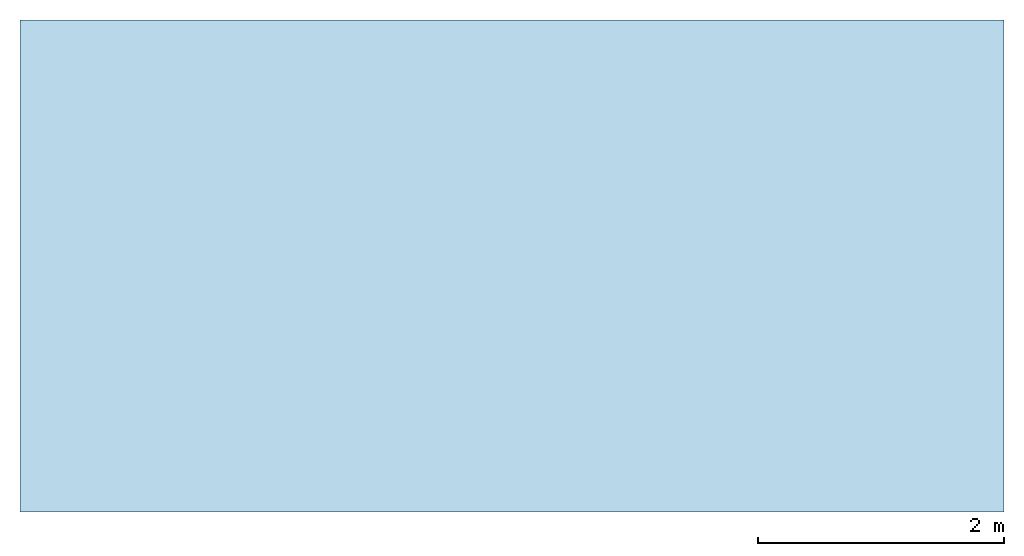
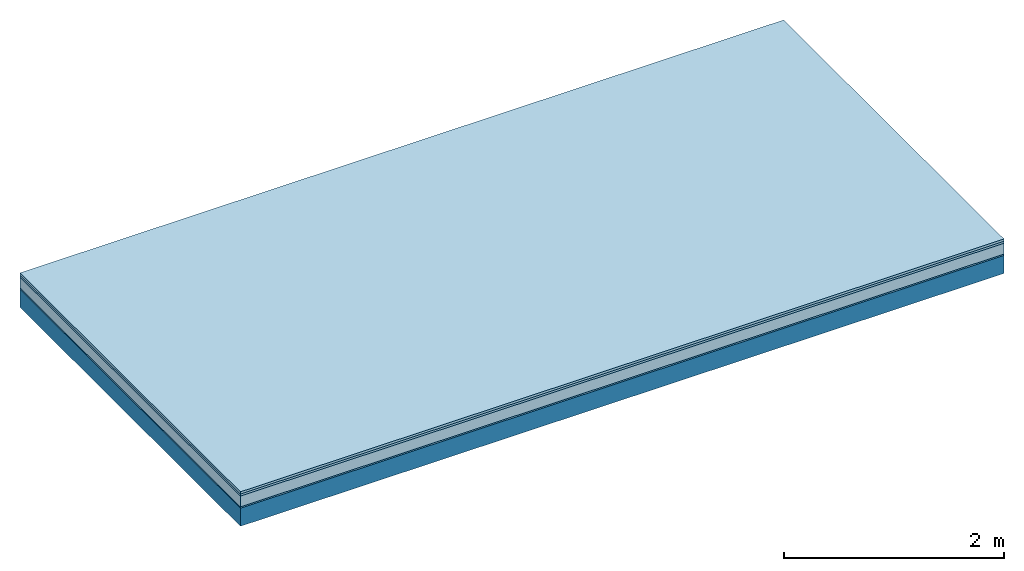
# One storey: 4 plates, 1 member, 1 element without a shape of its own.
"""IFC4 building model written with IfcOpenShell, lengths in metres."""

from ifc_helpers import new_model, si_unit, derived_unit, direction, frame, frame_2d, origin, origin_with_axes, place, context, project, spatial, rectangle, extrude, material, layer, layer_set, type_object, element, aggregate, save


model = new_model("IFC4")

# Units and contexts
plan_context = context("Plan", 3, precision=1e-05, world=origin(), true_north=direction((0.0, 1.0)))
model_context = context("Model", 3, precision=1e-05, world=origin(), true_north=direction((0.0, 1.0)))
ifc_project = project(units=[si_unit("LENGTHUNIT", "METRE"), derived_unit("SOUNDPRESSUREUNIT", [(si_unit("PRESSUREUNIT", "PASCAL", prefix="MICRO"), 0)]), si_unit("ENERGYUNIT", "JOULE", prefix="MEGA"), si_unit("MASSUNIT", "GRAM", prefix="KILO"), derived_unit("THERMALTRANSMITTANCEUNIT", [(si_unit("POWERUNIT", "WATT"), 1), (si_unit("AREAUNIT", "SQUARE_METRE"), -1), (si_unit("THERMODYNAMICTEMPERATUREUNIT", "KELVIN"), -1)]), derived_unit("AREADENSITYUNIT", [(si_unit("MASSUNIT", "GRAM", prefix="KILO"), 1), (si_unit("AREAUNIT", "SQUARE_METRE"), -1)]), derived_unit("USERDEFINED", [(si_unit("ENERGYUNIT", "JOULE", prefix="MEGA"), 1), (si_unit("AREAUNIT", "SQUARE_METRE"), -1)])], contexts=[plan_context, model_context])

# Site, building, storey
site = spatial("IfcSite", under=ifc_project)
building_placement = place(None, origin())
building = spatial("IfcBuilding", under=site, at=building_placement)
storey_placement = place(building_placement, origin())
storey = spatial("IfcBuildingStorey", under=building, at=storey_placement)

# Slab, member, plates
ifc_material_1 = material(Name="Floor heating system Therm38 longitudinal", Category="03.007")
ifc_layer_1 = layer(ifc_material_1, 0.025, Name="On-material")
ifc_material_2 = material(Category="10.009")
ifc_layer_2 = layer(ifc_material_2, 0.022, Name="Impact sound insulation")
ifc_material_3 = material(Category="03.011")
ifc_layer_3 = layer(ifc_material_3, 0.12, Name="on Supporting structure")
ifc_material_4 = material(Category="03.007")
ifc_layer_4 = layer(ifc_material_4, 0.015, Name="Sub-floor")
ifc_material_5 = material(Name="of the art")
ifc_layer_5 = layer(ifc_material_5, 0.0, Name="Bond")
ifc_layer_6 = layer(None, 0.2, Name="Supporting structure")
ifc_layer_set = layer_set([ifc_layer_1, ifc_layer_2, ifc_layer_3, ifc_layer_4, ifc_layer_5, ifc_layer_6])
slab_type = type_object("IfcSlabType", Name="A1106", PredefinedType="NOTDEFINED", material=ifc_layer_set)
slab_placement = place(None, frame((0.0, 0.0, 0.0), z_axis=(0.0, 0.0, -1.0), x_axis=(1.0, 0.0, 0.0)))
slab = element("IfcSlab", 1, at=slab_placement, inside=storey, type_object=slab_type, material=ifc_layer_set, Name="Slab #1")
ifc_material_6 = material()
member_placement = place(slab_placement, origin())
member = element("IfcMember", 2, at=member_placement, material=ifc_material_6, Name="Supporting structure", context=plan_context, shape_type="SweptSolid", body=[
    extrude(rectangle(XDim=1.0, YDim=0.2, at=frame_2d((0.5, 0.1), x_axis=(1.0, 0.0))), frame((0.0, 4.0, 0.182), z_axis=(0.0, -1.0, 0.0), x_axis=(1.0, 0.0, 0.0)), (0.0, 0.0, 1.0), 4.0),
    extrude(rectangle(XDim=1.0, YDim=0.2, at=frame_2d((0.5, 0.1), x_axis=(1.0, 0.0))), frame((1.0, 4.0, 0.182), z_axis=(0.0, -1.0, 0.0), x_axis=(1.0, 0.0, 0.0)), (0.0, 0.0, 1.0), 4.0),
    extrude(rectangle(XDim=1.0, YDim=0.2, at=frame_2d((0.5, 0.1), x_axis=(1.0, 0.0))), frame((2.0, 4.0, 0.182), z_axis=(0.0, -1.0, 0.0), x_axis=(1.0, 0.0, 0.0)), (0.0, 0.0, 1.0), 4.0),
    extrude(rectangle(XDim=1.0, YDim=0.2, at=frame_2d((0.5, 0.1), x_axis=(1.0, 0.0))), frame((3.0, 4.0, 0.182), z_axis=(0.0, -1.0, 0.0), x_axis=(1.0, 0.0, 0.0)), (0.0, 0.0, 1.0), 4.0),
    extrude(rectangle(XDim=1.0, YDim=0.2, at=frame_2d((0.5, 0.1), x_axis=(1.0, 0.0))), frame((4.0, 4.0, 0.182), z_axis=(0.0, -1.0, 0.0), x_axis=(1.0, 0.0, 0.0)), (0.0, 0.0, 1.0), 4.0),
    extrude(rectangle(XDim=1.0, YDim=0.2, at=frame_2d((0.5, 0.1), x_axis=(1.0, 0.0))), frame((5.0, 4.0, 0.182), z_axis=(0.0, -1.0, 0.0), x_axis=(1.0, 0.0, 0.0)), (0.0, 0.0, 1.0), 4.0),
    extrude(rectangle(XDim=1.0, YDim=0.2, at=frame_2d((0.5, 0.1), x_axis=(1.0, 0.0))), frame((6.0, 4.0, 0.182), z_axis=(0.0, -1.0, 0.0), x_axis=(1.0, 0.0, 0.0)), (0.0, 0.0, 1.0), 4.0),
    extrude(rectangle(XDim=1.0, YDim=0.2, at=frame_2d((0.5, 0.1), x_axis=(1.0, 0.0))), frame((7.0, 4.0, 0.182), z_axis=(0.0, -1.0, 0.0), x_axis=(1.0, 0.0, 0.0)), (0.0, 0.0, 1.0), 4.0),
])
plate_1_placement = place(slab_placement, origin())
plate_1 = element("IfcPlate", 3, at=plate_1_placement, material=ifc_material_1, Name="On-material", context=plan_context, shape_type="SweptSolid", body=[
    extrude(rectangle(XDim=8.0, YDim=4.0, at=frame_2d((4.0, 2.0), x_axis=(1.0, 0.0))), origin_with_axes(), (0.0, 0.0, 1.0), 0.025),
])
plate_2_placement = place(slab_placement, origin())
plate_2 = element("IfcPlate", 4, at=plate_2_placement, material=ifc_material_2, Name="Impact sound insulation", context=plan_context, shape_type="SweptSolid", body=[
    extrude(rectangle(XDim=8.0, YDim=4.0, at=frame_2d((4.0, 2.0), x_axis=(1.0, 0.0))), frame((0.0, 0.0, 0.025), z_axis=(0.0, 0.0, 1.0), x_axis=(1.0, 0.0, 0.0)), (0.0, 0.0, 1.0), 0.022),
])
plate_3_placement = place(slab_placement, origin())
plate_3 = element("IfcPlate", 5, at=plate_3_placement, material=ifc_material_3, Name="on Supporting structure", context=plan_context, shape_type="SweptSolid", body=[
    extrude(rectangle(XDim=8.0, YDim=4.0, at=frame_2d((4.0, 2.0), x_axis=(1.0, 0.0))), frame((0.0, 0.0, 0.047), z_axis=(0.0, 0.0, 1.0), x_axis=(1.0, 0.0, 0.0)), (0.0, 0.0, 1.0), 0.12),
])
plate_4_placement = place(slab_placement, origin())
plate_4 = element("IfcPlate", 6, at=plate_4_placement, material=ifc_material_4, Name="Sub-floor", context=plan_context, shape_type="SweptSolid", body=[
    extrude(rectangle(XDim=8.0, YDim=4.0, at=frame_2d((4.0, 2.0), x_axis=(1.0, 0.0))), frame((0.0, 0.0, 0.167), z_axis=(0.0, 0.0, 1.0), x_axis=(1.0, 0.0, 0.0)), (0.0, 0.0, 1.0), 0.015),
])
aggregate(slab, [plate_1, plate_2, plate_3, plate_4, member])

save(model, "model.ifc")
